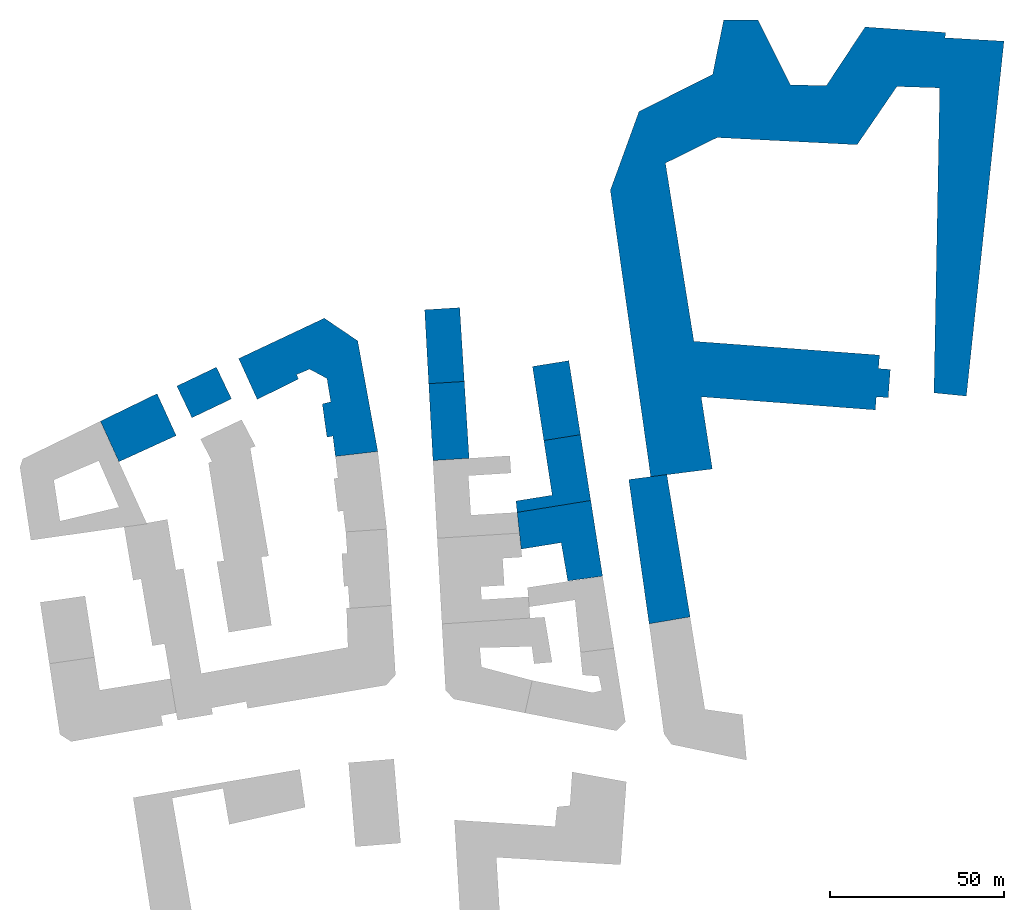
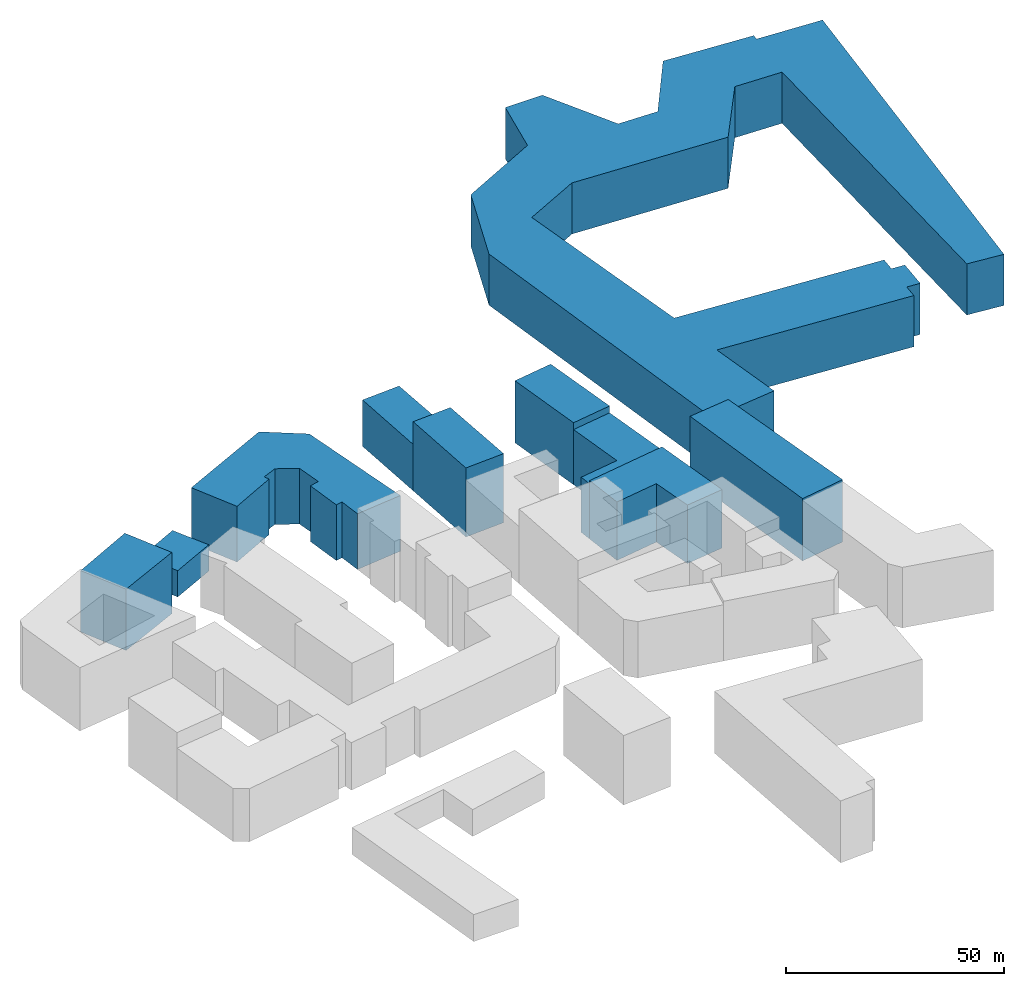
# One storey, part 2 of 2: 10 walls.
"""IFC2X3 building model written with IfcOpenShell, lengths in metres."""

from ifc_helpers import new_model, entity, si_unit, converted_unit, origin_with_axes, origin_2d_with_axis, place, context, subcontext, project, spatial, faceted_brep, element, save


model = new_model("IFC2X3")

# Units and contexts
model_context = context("Model", 3, precision=1e-05, world=origin_with_axes())
plan_context = context("Plan", 2, precision=1e-05, world=origin_2d_with_axis())
body_context = subcontext(model_context, "Body", "Model", "MODEL_VIEW")
ifc_project = project(units=[si_unit("AREAUNIT", "SQUARE_METRE"), si_unit("VOLUMEUNIT", "CUBIC_METRE"), si_unit("LENGTHUNIT", "METRE"), converted_unit("PLANEANGLEUNIT", "degree", entity("IfcReal", 0.0174532925199433), si_unit("PLANEANGLEUNIT", "RADIAN"), dimensions=[0, 0, 0, 0, 0, 0, 0])], contexts=[model_context, plan_context])

# Site, building, storey
site_placement = place(None, origin_with_axes())
site = spatial("IfcSite", under=ifc_project, at=site_placement, CompositionType="ELEMENT")
building_placement = place(site_placement, origin_with_axes())
building = spatial("IfcBuilding", under=site, at=building_placement, Name="Building", CompositionType="ELEMENT")
storey_placement = place(building_placement, origin_with_axes())
storey = spatial("IfcBuildingStorey", under=building, at=storey_placement, Name="Storey", CompositionType="ELEMENT")

# Walls
wall_1_placement = place(storey_placement, origin_with_axes())
element("IfcWall", 1, at=wall_1_placement, inside=storey, Name="map_2.buildings", context=body_context, shape_type="Brep", body=[
    faceted_brep([(144.879348754883, 62.6221809387207, 0.0), (144.577575683594, 58.737117767334, 14.3458013534546), (144.577575683594, 58.737117767334, 0.0), (91.4616088867188, 66.5837097167969, 0.0), (91.4616088867188, 66.5837097167969, 14.3458013534546), (144.879348754883, 62.6221809387207, 14.3458013534546), (83.2778549194336, 117.846168518066, 0.0), (98.1650085449219, 125.204696655273, 0.0), (98.1650085449219, 125.204696655273, 14.3458013534546), (83.2778549194336, 117.846168518066, 14.3458013534546), (138.424285888672, 123.135246276855, 0.0), (149.876937866211, 139.889205932617, 0.0), (138.424285888672, 123.135246276855, 14.3458013534546), (162.185501098633, 139.488891601562, 0.0), (149.876937866211, 139.889205932617, 14.3458013534546), (160.534591674805, 51.7468109130859, 0.0), (162.185501098633, 139.488891601562, 14.3458013534546), (169.855850219727, 50.8009490966797, 0.0), (160.534591674805, 51.7468109130859, 14.3458013534546), (180.682357788086, 152.925888061523, 0.0), (169.855850219727, 50.8009490966797, 14.3458013534546), (163.725891113281, 153.915954589844, 0.0), (180.682357788086, 152.925888061523, 14.3458013534546), (163.889358520508, 155.41877746582, 0.0), (163.725891113281, 153.915954589844, 14.3458013534546), (140.725158691406, 157.009841918945, 0.0), (163.889358520508, 155.41877746582, 14.3458013534546), (129.56184387207, 140.111190795898, 0.0), (140.725158691406, 157.009841918945, 14.3458013534546), (119.221908569336, 140.389205932617, 0.0), (129.56184387207, 140.111190795898, 14.3458013534546), (109.900398254395, 159.023834228516, 0.0), (119.221908569336, 140.389205932617, 14.3458013534546), (100.019645690918, 159.02360534668, 0.0), (109.900398254395, 159.023834228516, 14.3458013534546), (96.862678527832, 143.338607788086, 0.0), (100.019645690918, 159.02360534668, 14.3458013534546), (75.6924209594727, 132.740585327148, 0.0), (96.862678527832, 143.338607788086, 14.3458013534546), (67.4346466064453, 110.075798034668, 0.0), (75.6924209594727, 132.740585327148, 14.3458013534546), (79.0466384887695, 27.5993804931641, 0.0), (67.4346466064453, 110.075798034668, 14.3458013534546), (96.7708511352539, 29.8483905792236, 0.0), (79.0466384887695, 27.5993804931641, 14.3458013534546), (93.5626754760742, 50.6094055175781, 0.0), (96.7708511352539, 29.8483905792236, 14.3458013534546), (143.659683227539, 46.8370361328125, 0.0), (93.5626754760742, 50.6094055175781, 14.3458013534546), (143.955169677734, 50.6330413818359, 0.0), (143.659683227539, 46.8370361328125, 14.3458013534546), (147.376739501953, 50.3659858703613, 0.0), (147.376739501953, 50.3659858703613, 14.3458013534546), (143.955169677734, 50.6330413818359, 14.3458013534546), (147.986557006836, 58.4811973571777, 0.0), (147.986557006836, 58.4811973571777, 14.3458013534546)], [[[0, 1, 2]], [[0, 3, 4, 5]], [[6, 4, 3]], [[6, 7, 8, 9]], [[10, 8, 7]], [[11, 12, 10]], [[13, 14, 11]], [[15, 16, 13]], [[17, 18, 15]], [[19, 20, 17]], [[21, 22, 19]], [[23, 24, 21]], [[25, 26, 23]], [[27, 28, 25]], [[29, 30, 27]], [[31, 32, 29]], [[33, 34, 31]], [[35, 36, 33]], [[37, 38, 35]], [[39, 40, 37]], [[41, 42, 39]], [[43, 44, 41]], [[45, 46, 43]], [[47, 48, 45]], [[49, 50, 47]], [[49, 51, 52, 53]], [[54, 52, 51]], [[2, 55, 54]], [[0, 5, 1]], [[6, 9, 4]], [[10, 12, 8]], [[11, 14, 12]], [[13, 16, 14]], [[15, 18, 16]], [[17, 20, 18]], [[19, 22, 20]], [[21, 24, 22]], [[23, 26, 24]], [[25, 28, 26]], [[27, 30, 28]], [[29, 32, 30]], [[31, 34, 32]], [[33, 36, 34]], [[35, 38, 36]], [[37, 40, 38]], [[39, 42, 40]], [[41, 44, 42]], [[43, 46, 44]], [[45, 48, 46]], [[47, 50, 48]], [[49, 53, 50]], [[54, 55, 52]], [[2, 1, 55]]]),
    faceted_brep([(149.876937866211, 139.889205932617, 14.3458013534546), (162.185501098633, 139.488891601562, 14.3458013534546), (163.725891113281, 153.915954589844, 14.3458013534546), (144.577575683594, 58.737117767334, 14.3458013534546), (144.879348754883, 62.6221809387207, 14.3458013534546), (91.4616088867188, 66.5837097167969, 14.3458013534546), (147.376739501953, 50.3659858703613, 14.3458013534546), (147.986557006836, 58.4811973571777, 14.3458013534546), (143.955169677734, 50.6330413818359, 14.3458013534546), (93.5626754760742, 50.6094055175781, 14.3458013534546), (143.659683227539, 46.8370361328125, 14.3458013534546), (79.0466384887695, 27.5993804931641, 14.3458013534546), (96.7708511352539, 29.8483905792236, 14.3458013534546), (83.2778549194336, 117.846168518066, 14.3458013534546), (67.4346466064453, 110.075798034668, 14.3458013534546), (96.862678527832, 143.338607788086, 14.3458013534546), (75.6924209594727, 132.740585327148, 14.3458013534546), (98.1650085449219, 125.204696655273, 14.3458013534546), (109.900398254395, 159.023834228516, 14.3458013534546), (100.019645690918, 159.02360534668, 14.3458013534546), (119.221908569336, 140.389205932617, 14.3458013534546), (138.424285888672, 123.135246276855, 14.3458013534546), (129.56184387207, 140.111190795898, 14.3458013534546), (163.889358520508, 155.41877746582, 14.3458013534546), (140.725158691406, 157.009841918945, 14.3458013534546), (169.855850219727, 50.8009490966797, 14.3458013534546), (180.682357788086, 152.925888061523, 14.3458013534546), (160.534591674805, 51.7468109130859, 14.3458013534546)], [[[0, 1, 2]], [[3, 4, 5]], [[6, 7, 8]], [[7, 3, 8]], [[9, 10, 8]], [[8, 3, 9]], [[3, 5, 9]], [[11, 12, 9]], [[9, 5, 11]], [[5, 13, 14]], [[14, 11, 5]], [[15, 16, 17]], [[16, 14, 13]], [[17, 16, 13]], [[18, 19, 15]], [[20, 18, 15]], [[17, 21, 20]], [[21, 0, 22]], [[20, 15, 17]], [[23, 24, 2]], [[24, 22, 0]], [[2, 24, 0]], [[22, 20, 21]], [[25, 26, 1]], [[26, 2, 1]], [[1, 27, 25]]]),
])
wall_2_placement = place(storey_placement, origin_with_axes())
element("IfcWall", 2, at=wall_2_placement, inside=storey, Name="map_2.buildings", context=body_context, shape_type="Brep", body=[
    faceted_brep([(-52.9479675292969, 44.5863380432129, 0.0), (-57.3002777099609, 53.7034606933594, 7.37306976318359), (-57.3002777099609, 53.7034606933594, 0.0), (-45.9160041809082, 59.1357192993164, 7.37306976318359), (-45.9160041809082, 59.1357192993164, 0.0), (-41.5636749267578, 50.0186080932617, 7.37306976318359), (-41.5636749267578, 50.0186080932617, 0.0), (-52.9479675292969, 44.5863380432129, 7.37306976318359)], [[[0, 1, 2]], [[2, 3, 4]], [[4, 5, 6]], [[6, 7, 0]], [[0, 7, 1]], [[2, 1, 3]], [[4, 3, 5]], [[6, 5, 7]]]),
    faceted_brep([(-57.3002777099609, 53.7034606933594, 7.37306976318359), (-52.9479675292969, 44.5863380432129, 7.37306976318359), (-41.5636749267578, 50.0186080932617, 7.37306976318359), (-45.9160041809082, 59.1357192993164, 7.37306976318359)], [[[0, 1, 2, 3]]]),
])
wall_3_placement = place(storey_placement, origin_with_axes())
element("IfcWall", 3, at=wall_3_placement, inside=storey, Name="map_2.buildings", context=body_context, shape_type="Brep", body=[
    faceted_brep([(83.6758117675781, 28.2451190948486, 0.0), (90.3751449584961, -12.6980562210083, 17.4734878540039), (90.3751449584961, -12.6980562210083, 0.0), (78.588249206543, -14.7020349502563, 17.4734878540039), (78.588249206543, -14.7020349502563, 0.0), (72.7255401611328, 26.8089008331299, 0.0), (72.7255401611328, 26.8089008331299, 17.4734878540039), (83.6758117675781, 28.2451190948486, 17.4734878540039)], [[[0, 1, 2]], [[2, 3, 4]], [[5, 4, 3, 6]], [[0, 5, 6, 7]], [[0, 7, 1]], [[2, 1, 3]]]),
    faceted_brep([(90.3751449584961, -12.6980562210083, 17.4734878540039), (83.6758117675781, 28.2451190948486, 17.4734878540039), (72.7255401611328, 26.8089008331299, 17.4734878540039), (78.588249206543, -14.7020349502563, 17.4734878540039)], [[[0, 1, 2, 3]]]),
])
wall_4_placement = place(storey_placement, origin_with_axes())
element("IfcWall", 4, at=wall_4_placement, inside=storey, Name="map_2.buildings", context=body_context, shape_type="Brep", body=[
    faceted_brep([(55.4851417541504, 61.0171279907227, 0.0), (45.0318260192871, 59.3472137451172, 0.0), (45.0318260192871, 59.3472137451172, 17.3990669250488), (55.4851417541504, 61.0171279907227, 17.3990669250488), (58.8189239501953, 39.721752166748, 17.3990669250488), (58.8189239501953, 39.721752166748, 0.0), (48.2963714599609, 38.040699005127, 0.0), (48.2963714599609, 38.040699005127, 17.3990669250488)], [[[0, 1, 2, 3]], [[0, 4, 5]], [[6, 5, 4, 7]], [[6, 2, 1]], [[0, 3, 4]], [[6, 7, 2]]]),
    faceted_brep([(55.4851417541504, 61.0171279907227, 17.3990669250488), (45.0318260192871, 59.3472137451172, 17.3990669250488), (48.2963714599609, 38.040699005127, 17.3990669250488), (58.8189239501953, 39.721752166748, 17.3990669250488)], [[[0, 1, 2, 3]]]),
])
wall_5_placement = place(storey_placement, origin_with_axes())
element("IfcWall", 5, at=wall_5_placement, inside=storey, Name="map_2.buildings", context=body_context, shape_type="Brep", body=[
    faceted_brep([(25.4082527160645, 55.0389938354492, 0.0), (15.1750421524048, 54.3932914733887, 13.0005474090576), (15.1750421524048, 54.3932914733887, 0.0), (14.0051050186157, 75.6441802978516, 0.0), (14.0051050186157, 75.6441802978516, 13.0005474090576), (24.0810260772705, 76.2787475585938, 13.0005474090576), (24.0810260772705, 76.2787475585938, 0.0), (25.4082527160645, 55.0389938354492, 13.0005474090576)], [[[0, 1, 2]], [[3, 2, 1, 4]], [[3, 5, 6]], [[6, 7, 0]], [[0, 7, 1]], [[3, 4, 5]], [[6, 5, 7]]]),
    faceted_brep([(15.1750421524048, 54.3932914733887, 13.0005474090576), (25.4082527160645, 55.0389938354492, 13.0005474090576), (24.0810260772705, 76.2787475585938, 13.0005474090576), (14.0051050186157, 75.6441802978516, 13.0005474090576)], [[[0, 1, 2, 3]]]),
])
wall_6_placement = place(storey_placement, origin_with_axes())
element("IfcWall", 6, at=wall_6_placement, inside=storey, Name="map_2.buildings", context=body_context, shape_type="Brep", body=[
    faceted_brep([(26.7921047210693, 32.9198188781738, 0.0), (25.4082527160645, 55.0389938354492, 0.0), (25.4082527160645, 55.0389938354492, 19.3760795593262), (26.7921047210693, 32.9198188781738, 19.3760795593262), (16.3953113555908, 32.274112701416, 19.3760795593262), (16.3953113555908, 32.274112701416, 0.0), (15.1750421524048, 54.3932914733887, 0.0), (15.1750421524048, 54.3932914733887, 19.3760795593262)], [[[0, 1, 2, 3]], [[0, 4, 5]], [[6, 5, 4, 7]], [[6, 2, 1]], [[0, 3, 4]], [[6, 7, 2]]]),
    faceted_brep([(26.7921047210693, 32.9198188781738, 19.3760795593262), (15.1750421524048, 54.3932914733887, 19.3760795593262), (16.3953113555908, 32.274112701416, 19.3760795593262), (25.4082527160645, 55.0389938354492, 19.3760795593262)], [[[0, 1, 2]], [[0, 3, 1]]]),
])
wall_7_placement = place(storey_placement, origin_with_axes())
element("IfcWall", 7, at=wall_7_placement, inside=storey, Name="map_2.buildings", context=body_context, shape_type="Brep", body=[
    faceted_brep([(48.2963714599609, 38.040699005127, 0.0), (50.6991996765137, 22.3112831115723, 0.0), (50.6991996765137, 22.3112831115723, 15.4795579910278), (48.2963714599609, 38.040699005127, 15.4795579910278), (58.8189239501953, 39.721752166748, 15.4795579910278), (58.8189239501953, 39.721752166748, 0.0), (61.7879028320312, 20.7863483428955, 15.4795579910278), (61.7879028320312, 20.7863483428955, 0.0), (40.6231956481934, 17.3685932159424, 15.4795579910278), (40.6231956481934, 17.3685932159424, 0.0), (40.2709426879883, 20.6413822174072, 15.4795579910278), (40.2709426879883, 20.6413822174072, 0.0)], [[[0, 1, 2, 3]], [[0, 4, 5]], [[5, 6, 7]], [[7, 8, 9]], [[9, 10, 11]], [[11, 2, 1]], [[0, 3, 4]], [[5, 4, 6]], [[7, 6, 8]], [[9, 8, 10]], [[11, 10, 2]]]),
    faceted_brep([(48.2963714599609, 38.040699005127, 15.4795579910278), (50.6991996765137, 22.3112831115723, 15.4795579910278), (40.2709426879883, 20.6413822174072, 15.4795579910278), (40.6231956481934, 17.3685932159424, 15.4795579910278), (61.7879028320312, 20.7863483428955, 15.4795579910278), (58.8189239501953, 39.721752166748, 15.4795579910278)], [[[0, 1, 2, 3, 4, 5]]]),
])
wall_8_placement = place(storey_placement, origin_with_axes())
element("IfcWall", 8, at=wall_8_placement, inside=storey, Name="map_2.buildings", context=body_context, shape_type="Brep", body=[
    faceted_brep([(40.6231956481934, 17.3685932159424, 0.0), (41.7617263793945, 6.79325199127197, 0.0), (41.7617263793945, 6.79325199127197, 16.3944892883301), (40.6231956481934, 17.3685932159424, 16.3944892883301), (61.7879028320312, 20.7863483428955, 16.3944892883301), (61.7879028320312, 20.7863483428955, 0.0), (65.1972274780273, -0.976562023162842, 16.3944892883301), (65.1972274780273, -0.976562023162842, 0.0), (55.1840438842773, -2.36819410324097, 16.3944892883301), (55.1840438842773, -2.36819410324097, 0.0), (53.2844161987305, 8.65241241455078, 0.0), (53.2844161987305, 8.65241241455078, 16.3944892883301)], [[[0, 1, 2, 3]], [[0, 4, 5]], [[5, 6, 7]], [[7, 8, 9]], [[10, 9, 8, 11]], [[1, 10, 11, 2]], [[0, 3, 4]], [[5, 4, 6]], [[7, 6, 8]]]),
    faceted_brep([(53.2844161987305, 8.65241241455078, 16.3944892883301), (65.1972274780273, -0.976562023162842, 16.3944892883301), (61.7879028320312, 20.7863483428955, 16.3944892883301), (40.6231956481934, 17.3685932159424, 16.3944892883301), (41.7617263793945, 6.79325199127197, 16.3944892883301), (55.1840438842773, -2.36819410324097, 16.3944892883301)], [[[0, 1, 2]], [[2, 3, 0]], [[3, 4, 0]], [[0, 5, 1]]]),
])
wall_9_placement = place(storey_placement, origin_with_axes())
element("IfcWall", 9, at=wall_9_placement, inside=storey, Name="map_2.buildings", context=body_context, shape_type="Brep", body=[
    faceted_brep([(0.526516020298004, 34.8900909423828, 0.0), (-5.25992298126221, 66.7274703979492, 0.0), (-5.25992298126221, 66.7274703979492, 15.6243858337402), (0.526516020298004, 34.8900909423828, 15.6243858337402), (-11.6691188812256, 33.465217590332, 15.6243858337402), (-11.6691188812256, 33.465217590332, 0.0), (-12.3924121856689, 39.3094940185547, 0.0), (-12.3924121856689, 39.3094940185547, 15.6243858337402), (-14.103196144104, 38.997802734375, 15.6243858337402), (-14.103196144104, 38.997802734375, 0.0), (-15.4428567886353, 48.5824165344238, 0.0), (-15.4428567886353, 48.5824165344238, 15.6243858337402), (-12.9961881637573, 49.1612701416016, 15.6243858337402), (-12.9961881637573, 49.1612701416016, 0.0), (-14.103141784668, 55.8849716186523, 0.0), (-14.103141784668, 55.8849716186523, 15.6243858337402), (-19.1096668243408, 58.5789222717285, 15.6243858337402), (-19.1096668243408, 58.5789222717285, 0.0), (-22.8331279754639, 56.9870681762695, 15.6243858337402), (-22.8331279754639, 56.9870681762695, 0.0), (-22.3110961914062, 55.6957626342773, 15.6243858337402), (-22.3110961914062, 55.6957626342773, 0.0), (-34.1544952392578, 49.8738288879395, 0.0), (-34.1544952392578, 49.8738288879395, 15.6243858337402), (-39.5068626403809, 61.6180801391602, 15.6243858337402), (-39.5068626403809, 61.6180801391602, 0.0), (-14.8641262054443, 73.2285461425781, 15.6243858337402), (-14.8641262054443, 73.2285461425781, 0.0)], [[[0, 1, 2, 3]], [[0, 4, 5]], [[6, 5, 4, 7]], [[6, 8, 9]], [[10, 9, 8, 11]], [[10, 12, 13]], [[14, 13, 12, 15]], [[14, 16, 17]], [[17, 18, 19]], [[19, 20, 21]], [[22, 21, 20, 23]], [[22, 24, 25]], [[25, 26, 27]], [[27, 2, 1]], [[0, 3, 4]], [[6, 7, 8]], [[10, 11, 12]], [[14, 15, 16]], [[17, 16, 18]], [[19, 18, 20]], [[22, 23, 24]], [[25, 24, 26]], [[27, 26, 2]]]),
    faceted_brep([(-5.25992298126221, 66.7274703979492, 15.6243858337402), (-14.103141784668, 55.8849716186523, 15.6243858337402), (-12.9961881637573, 49.1612701416016, 15.6243858337402), (-11.6691188812256, 33.465217590332, 15.6243858337402), (0.526516020298004, 34.8900909423828, 15.6243858337402), (-12.3924121856689, 39.3094940185547, 15.6243858337402), (-14.8641262054443, 73.2285461425781, 15.6243858337402), (-19.1096668243408, 58.5789222717285, 15.6243858337402), (-39.5068626403809, 61.6180801391602, 15.6243858337402), (-22.8331279754639, 56.9870681762695, 15.6243858337402), (-34.1544952392578, 49.8738288879395, 15.6243858337402), (-22.3110961914062, 55.6957626342773, 15.6243858337402), (-15.4428567886353, 48.5824165344238, 15.6243858337402), (-14.103196144104, 38.997802734375, 15.6243858337402)], [[[0, 1, 2]], [[3, 4, 5]], [[4, 0, 2]], [[5, 4, 2]], [[0, 6, 7]], [[6, 8, 9]], [[8, 10, 9]], [[10, 11, 9]], [[12, 13, 5]], [[2, 12, 5]], [[6, 9, 7]], [[0, 7, 1]]]),
])
wall_10_placement = place(storey_placement, origin_with_axes())
element("IfcWall", 10, at=wall_10_placement, inside=storey, Name="map_2.buildings", context=body_context, shape_type="Brep", body=[
    faceted_brep([(-73.95556640625, 31.9296188354492, 0.0), (-57.4828643798828, 39.4545669555664, 0.0), (-57.4828643798828, 39.4545669555664, 17.2089443206787), (-73.95556640625, 31.9296188354492, 17.2089443206787), (-79.2701110839844, 43.6071281433105, 17.2089443206787), (-79.2701110839844, 43.6071281433105, 0.0), (-62.9861259460449, 51.5216789245605, 17.2089443206787), (-62.9861259460449, 51.5216789245605, 0.0)], [[[0, 1, 2, 3]], [[0, 4, 5]], [[5, 6, 7]], [[7, 2, 1]], [[0, 3, 4]], [[5, 4, 6]], [[7, 6, 2]]]),
    faceted_brep([(-73.95556640625, 31.9296188354492, 17.2089443206787), (-57.4828643798828, 39.4545669555664, 17.2089443206787), (-62.9861259460449, 51.5216789245605, 17.2089443206787), (-79.2701110839844, 43.6071281433105, 17.2089443206787)], [[[0, 1, 2, 3]]]),
])

save(model, "model.ifc")
